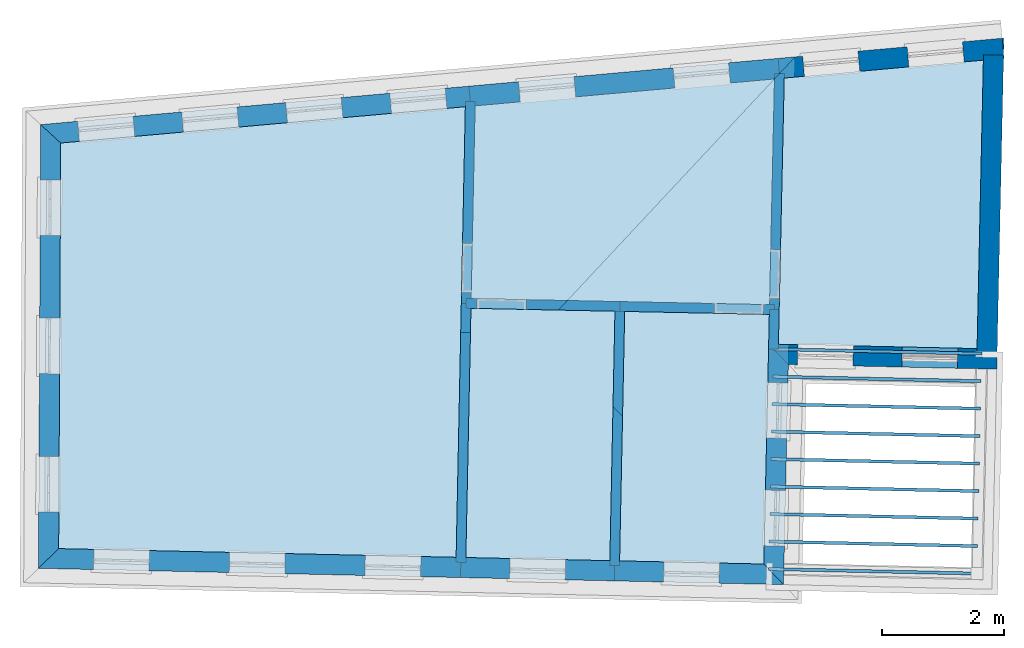
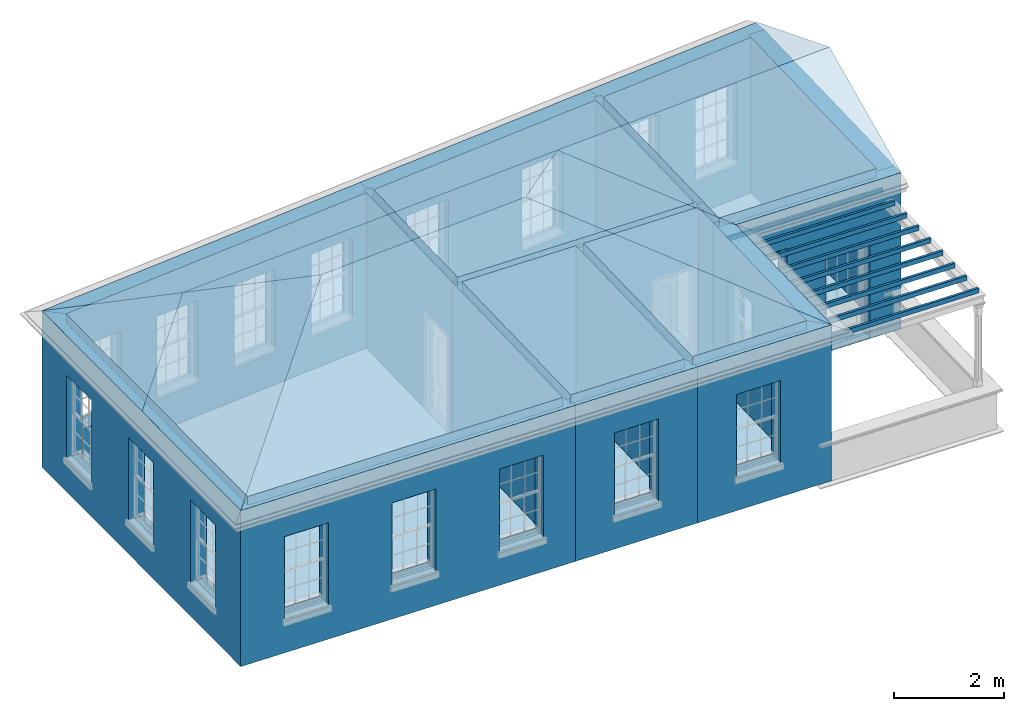
# One storey, part 1 of 14: 18 slabs, 17 walls, 2 roofs, 24 openings.
"""IFC2X3 building model written with IfcOpenShell, lengths in metres."""

from ifc_helpers import new_model, si_unit, frame, origin, place, context, subcontext, project, spatial, polyline, outline, extrude, faceted_brep, material, layer, layer_set, layer_usage, element, save


model = new_model("IFC2X3")

# Units and contexts
model_context = context("Model", 3, world=origin())
body_context = subcontext(model_context, "Body", "Model", "MODEL_VIEW")
ifc_project = project(units=[si_unit("PLANEANGLEUNIT", "RADIAN"), si_unit("MASSUNIT", "GRAM", prefix="KILO"), si_unit("FORCEUNIT", "NEWTON", prefix="KILO"), si_unit("LENGTHUNIT", "METRE")], contexts=[model_context])

# Site, building, storey
site_placement = place(None, origin())
site = spatial("IfcSite", under=ifc_project, at=site_placement, CompositionType="ELEMENT")
building_placement = place(None, origin())
building = spatial("IfcBuilding", under=site, at=building_placement, Name="Building plot-17", CompositionType="ELEMENT")
storey_placement = place(None, frame((0.0, 0.0, 6.15)))
storey = spatial("IfcBuildingStorey", under=building, at=storey_placement, Name="Floor 1", CompositionType="ELEMENT", Elevation=6.15)

# Slabs
slab_1_placement = place(storey_placement, frame((0.0, 0.0, 3.25)))
element("IfcSlab", 1, at=slab_1_placement, inside=storey, Name="Slab", ObjectType="Slab", PredefinedType="FLOOR", context=body_context, shape_type="SweptSolid", body=[
    extrude(outline(polyline([(85.7393487222941, 22.0938601884115), (85.8425989058895, 26.8144504761044), (82.5834149093309, 26.5217011344998), (82.488123206876, 22.1649719797169), (85.7393487222941, 22.0938601884115)])), origin(), (0.0, 0.0, 1.0), 0.2),
])
slab_2_placement = place(storey_placement, frame((0.0, 0.0, 2.95)))
element("IfcSlab", 2, at=slab_2_placement, inside=storey, Name="Slab", ObjectType="Slab", PredefinedType="FLOOR", context=body_context, shape_type="SweptSolid", body=[
    extrude(outline(polyline([(85.7382573208304, 18.3854928925304), (85.739350674509, 18.4354809368784), (82.3281634171773, 18.5100914599554), (82.3270700634987, 18.4601034156075), (85.7382573208304, 18.3854928925304)])), origin(), (0.0, 0.0, 1.0), 0.1),
])
slab_3_placement = place(storey_placement, frame((0.0, 0.0, 2.95)))
element("IfcSlab", 3, at=slab_3_placement, inside=storey, Name="Slab", ObjectType="Slab", PredefinedType="FLOOR", context=body_context, shape_type="SweptSolid", body=[
    extrude(outline(polyline([(85.7480975039383, 18.835385291662), (85.749190857617, 18.88537333601), (82.3380036002853, 18.959983859087), (82.3369102466066, 18.9099958147391), (85.7480975039383, 18.835385291662)])), origin(), (0.0, 0.0, 1.0), 0.1),
])
slab_4_placement = place(storey_placement, frame((0.0, 0.0, 2.95)))
element("IfcSlab", 4, at=slab_4_placement, inside=storey, Name="Slab", ObjectType="Slab", PredefinedType="FLOOR", context=body_context, shape_type="SweptSolid", body=[
    extrude(outline(polyline([(85.7579376870462, 19.2852776907937), (85.7590310407249, 19.3352657351416), (82.3478437833932, 19.4098762582186), (82.3467504297146, 19.3598882138707), (85.7579376870462, 19.2852776907937)])), origin(), (0.0, 0.0, 1.0), 0.1),
])
slab_5_placement = place(storey_placement, frame((0.0, 0.0, 2.95)))
element("IfcSlab", 5, at=slab_5_placement, inside=storey, Name="Slab", ObjectType="Slab", PredefinedType="FLOOR", context=body_context, shape_type="SweptSolid", body=[
    extrude(outline(polyline([(85.7677778701542, 19.7351700899253), (85.7688712238328, 19.7851581342732), (82.3576839665012, 19.8597686573503), (82.3565906128225, 19.8097806130023), (85.7677778701542, 19.7351700899253)])), origin(), (0.0, 0.0, 1.0), 0.1),
])
slab_6_placement = place(storey_placement, frame((0.0, 0.0, 2.95)))
element("IfcSlab", 6, at=slab_6_placement, inside=storey, Name="Slab", ObjectType="Slab", PredefinedType="FLOOR", context=body_context, shape_type="SweptSolid", body=[
    extrude(outline(polyline([(85.7776180532621, 20.1850624890569), (85.7787114069408, 20.2350505334048), (82.3675241496091, 20.3096610564819), (82.3664307959305, 20.2596730121339), (85.7776180532621, 20.1850624890569)])), origin(), (0.0, 0.0, 1.0), 0.1),
])
slab_7_placement = place(storey_placement, frame((0.0, 0.0, 2.95)))
element("IfcSlab", 7, at=slab_7_placement, inside=storey, Name="Slab", ObjectType="Slab", PredefinedType="FLOOR", context=body_context, shape_type="SweptSolid", body=[
    extrude(outline(polyline([(85.78745823637, 20.6349548881885), (85.7885515900487, 20.6849429325365), (82.3773643327171, 20.7595534556135), (82.3762709790384, 20.7095654112655), (85.78745823637, 20.6349548881885)])), origin(), (0.0, 0.0, 1.0), 0.1),
])
slab_8_placement = place(storey_placement, frame((0.0, 0.0, 2.95)))
element("IfcSlab", 8, at=slab_8_placement, inside=storey, Name="Slab", ObjectType="Slab", PredefinedType="FLOOR", context=body_context, shape_type="SweptSolid", body=[
    extrude(outline(polyline([(85.797298419478, 21.0848472873201), (85.7983917731566, 21.1348353316681), (82.387204515825, 21.2094458547451), (82.3861111621463, 21.1594578103972), (85.797298419478, 21.0848472873201)])), origin(), (0.0, 0.0, 1.0), 0.1),
])
slab_9_placement = place(storey_placement, frame((0.0, 0.0, 2.95)))
element("IfcSlab", 9, at=slab_9_placement, inside=storey, Name="Slab", ObjectType="Slab", PredefinedType="FLOOR", context=body_context, shape_type="SweptSolid", body=[
    extrude(outline(polyline([(85.8071386025859, 21.5347396864517), (85.8082319562646, 21.5847277307997), (82.397044698933, 21.6593382538767), (82.3959513452543, 21.6093502095288), (85.8071386025859, 21.5347396864517)])), origin(), (0.0, 0.0, 1.0), 0.1),
])
slab_10_placement = place(storey_placement, frame((0.0, 0.0, 2.95)))
element("IfcSlab", 10, at=slab_10_placement, inside=storey, Name="Slab", ObjectType="Slab", PredefinedType="FLOOR", context=body_context, shape_type="SweptSolid", body=[
    extrude(outline(polyline([(85.8169787856938, 21.9846320855834), (85.8180721393725, 22.0346201299313), (82.4068848820409, 22.1092306530083), (82.4057915283622, 22.0592426086604), (85.8169787856938, 21.9846320855834)])), origin(), (0.0, 0.0, 1.0), 0.1),
])
slab_11_placement = place(storey_placement, frame((0.0, 0.0, 3.25)))
element("IfcSlab", 11, at=slab_11_placement, inside=storey, Name="Slab", ObjectType="Slab", PredefinedType="FLOOR", context=body_context, shape_type="SweptSolid", body=[
    extrude(outline(polyline([(77.3625338918575, 26.0527464875477), (70.7400454135505, 25.4578954009408), (70.7063349193503, 18.8193007747523), (77.2119597454112, 18.6770077739289), (77.3625338918575, 26.0527464875477)])), origin(), (0.0, 0.0, 1.0), 0.2),
])
slab_12_placement = place(storey_placement, frame((0.0, 0.0, 3.25)))
element("IfcSlab", 12, at=slab_12_placement, inside=storey, Name="Slab", ObjectType="Slab", PredefinedType="FLOOR", context=body_context, shape_type="SweptSolid", body=[
    extrude(outline(polyline([(77.3719216570803, 18.6735090384441), (79.728438199853, 18.6219665933562), (79.8117822482766, 22.7044996112409), (77.4551956168955, 22.7526088290867), (77.3719216570803, 18.6735090384441)])), origin(), (0.0, 0.0, 1.0), 0.2),
])
slab_13_placement = place(storey_placement, frame((0.0, 0.0, 3.25)))
element("IfcSlab", 13, at=slab_13_placement, inside=storey, Name="Slab", ObjectType="Slab", PredefinedType="FLOOR", context=body_context, shape_type="SweptSolid", body=[
    extrude(outline(polyline([(82.3422560462478, 22.812873861267), (82.4230616066043, 26.5072977366408), (77.5228612241715, 26.0671475526688), (77.4584613026294, 22.912575498417), (82.3422560462478, 22.812873861267)])), origin(), (0.0, 0.0, 1.0), 0.2),
])
slab_14_placement = place(storey_placement, frame((0.0, 0.0, 3.25)))
element("IfcSlab", 14, at=slab_14_placement, inside=storey, Name="Slab", ObjectType="Slab", PredefinedType="FLOOR", context=body_context, shape_type="SweptSolid", body=[
    extrude(outline(polyline([(79.8884001115221, 18.6184678578716), (82.2493852352671, 18.5668276746241), (82.3387573107631, 22.6529119495976), (79.9717489176071, 22.701233925507), (79.8884001115221, 18.6184678578716)])), origin(), (0.0, 0.0, 1.0), 0.2),
])
slab_15_placement = place(storey_placement, origin())
element("IfcSlab", 15, at=slab_15_placement, inside=storey, Name="Slab", ObjectType="Slab", PredefinedType="FLOOR", context=body_context, shape_type="SweptSolid", body=[
    extrude(outline(polyline([(85.7393487222941, 22.0938601884115), (85.8425989058895, 26.8144504761044), (82.5834149093309, 26.5217011344998), (82.488123206876, 22.1649719797169), (85.7393487222941, 22.0938601884115)])), origin(), (0.0, 0.0, 1.0), 0.02),
])
slab_16_placement = place(storey_placement, origin())
element("IfcSlab", 16, at=slab_16_placement, inside=storey, Name="Slab", ObjectType="Slab", PredefinedType="FLOOR", context=body_context, shape_type="SweptSolid", body=[
    extrude(outline(polyline([(77.3625338918575, 26.0527464875477), (70.7400454135505, 25.4578954009408), (70.7063349193503, 18.8193007747523), (77.2119597454112, 18.6770077739289), (77.3625338918575, 26.0527464875477)])), origin(), (0.0, 0.0, 1.0), 0.02),
])
slab_17_placement = place(storey_placement, origin())
element("IfcSlab", 17, at=slab_17_placement, inside=storey, Name="Slab", ObjectType="Slab", PredefinedType="FLOOR", context=body_context, shape_type="SweptSolid", body=[
    extrude(outline(polyline([(77.3719216570803, 18.6735090384441), (79.728438199853, 18.6219665933562), (79.8117822482766, 22.7044996112409), (77.4551956168955, 22.7526088290867), (77.3719216570803, 18.6735090384441)])), origin(), (0.0, 0.0, 1.0), 0.02),
])
slab_18_placement = place(storey_placement, origin())
element("IfcSlab", 18, at=slab_18_placement, inside=storey, Name="Slab", ObjectType="Slab", PredefinedType="FLOOR", context=body_context, shape_type="SweptSolid", body=[
    extrude(outline(polyline([(79.8884001115221, 18.6184678578716), (82.2493852352671, 18.5668276746241), (82.3387573107631, 22.6529119495976), (79.9717489176071, 22.701233925507), (79.8884001115221, 18.6184678578716)])), origin(), (0.0, 0.0, 1.0), 0.02),
])

# Wall, openings
ifc_material_1 = material(Name="Masonry")
ifc_layer_1 = layer(ifc_material_1, 0.33, ventilated=False)
ifc_layer_set_1 = layer_set([ifc_layer_1], Name="My Wall")
ifc_layer_usage_1 = layer_usage(ifc_layer_set_1, "AXIS2", "NEGATIVE", 0.08)
wall_1_placement = place(storey_placement, origin())
wall_1 = element("IfcWallStandardCase", 19, at=wall_1_placement, inside=storey, material=ifc_layer_usage_1, Name="exterior", context=body_context, shape_type="SweptSolid", body=[
    extrude(outline(polyline([(86.1806904049411, 26.8448188332919), (86.1511677071765, 27.173495589873), (82.4826328650269, 26.8439771702856), (82.5121555627915, 26.5153004137045), (86.1806904049411, 26.8448188332919)])), origin(), (0.0, 0.0, 1.0), 3.45),
])
opening_1_placement = place(storey_placement, frame((0.0, 0.0, 0.75)))
element("IfcOpeningElement", 20, at=opening_1_placement, cuts=wall_1, Name="Opening", ObjectType="Opening", context=body_context, shape_type="SweptSolid", body=[
    extrude(outline(polyline([(85.5004613675041, 27.1150472627096), (84.5941103114773, 27.0336361870557), (84.6236330092419, 26.7049594304745), (85.5299840652687, 26.7863705061284), (85.5004613675041, 27.1150472627096)])), origin(), (0.0, 0.0, 1.0), 1.82),
])
opening_2_placement = place(storey_placement, frame((0.0, 0.0, 0.75)))
element("IfcOpeningElement", 21, at=opening_2_placement, cuts=wall_1, Name="Opening", ObjectType="Opening", context=body_context, shape_type="SweptSolid", body=[
    extrude(outline(polyline([(83.7906927178616, 26.9614708929782), (82.8843416618348, 26.8800598173243), (82.9138643595994, 26.5513830607432), (83.8202154156262, 26.6327941363971), (83.7906927178616, 26.9614708929782)])), origin(), (0.0, 0.0, 1.0), 1.82),
])

wall_2_placement = place(storey_placement, origin())
wall_2 = element("IfcWallStandardCase", 22, at=wall_2_placement, inside=storey, material=ifc_layer_usage_1, Name="exterior", context=body_context, shape_type="SweptSolid", body=[
    extrude(outline(polyline([(82.5121555627915, 26.5153004137045), (82.4826328650269, 26.8439771702856), (77.4219746484992, 26.3894141991445), (77.4514973462638, 26.0607374425634), (82.5121555627915, 26.5153004137045)])), origin(), (0.0, 0.0, 1.0), 3.45),
])
opening_3_placement = place(storey_placement, frame((0.0, 0.0, 0.75)))
element("IfcOpeningElement", 23, at=opening_3_placement, cuts=wall_2, Name="Opening", ObjectType="Opening", context=body_context, shape_type="SweptSolid", body=[
    extrude(outline(polyline([(81.6706438389084, 26.7710419653273), (80.7642927828816, 26.6896308896734), (80.7938154806462, 26.3609541330922), (81.700166536673, 26.4423652087461), (81.6706438389084, 26.7710419653273)])), origin(), (0.0, 0.0, 1.0), 1.82),
])
opening_4_placement = place(storey_placement, frame((0.0, 0.0, 0.75)))
element("IfcOpeningElement", 24, at=opening_4_placement, cuts=wall_2, Name="Opening", ObjectType="Opening", context=body_context, shape_type="SweptSolid", body=[
    extrude(outline(polyline([(79.1403147306445, 26.5437604797567), (78.2339636746177, 26.4623494041028), (78.2634863723823, 26.1336726475217), (79.1698374284091, 26.2150837231756), (79.1403147306445, 26.5437604797567)])), origin(), (0.0, 0.0, 1.0), 1.82),
])

wall_3_placement = place(storey_placement, origin())
wall_3 = element("IfcWallStandardCase", 25, at=wall_3_placement, inside=storey, material=ifc_layer_usage_1, Name="exterior", context=body_context, shape_type="SweptSolid", body=[
    extrude(outline(polyline([(77.4514973462638, 26.0607374425634), (77.4219746484992, 26.3894141991445), (70.4115738095909, 25.7597197013384), (70.7400454135505, 25.4578954009408), (77.4514973462638, 26.0607374425634)])), origin(), (0.0, 0.0, 1.0), 3.45),
])
opening_5_placement = place(storey_placement, frame((0.0, 0.0, 0.75)))
element("IfcOpeningElement", 26, at=opening_5_placement, cuts=wall_3, Name="Opening", ObjectType="Opening", context=body_context, shape_type="SweptSolid", body=[
    extrude(outline(polyline([(77.0323071544384, 26.354413136777), (76.1259560984116, 26.273002061123), (76.1554787961762, 25.9443253045419), (77.061829852203, 26.0257363801958), (77.0323071544384, 26.354413136777)])), origin(), (0.0, 0.0, 1.0), 1.82),
])
opening_6_placement = place(storey_placement, frame((0.0, 0.0, 0.75)))
element("IfcOpeningElement", 27, at=opening_6_placement, cuts=wall_3, Name="Opening", ObjectType="Opening", context=body_context, shape_type="SweptSolid", body=[
    extrude(outline(polyline([(75.3291639612452, 26.201431884724), (74.4228129052184, 26.12002080907), (74.452335602983, 25.7913440524889), (75.3586866590098, 25.8727551281428), (75.3291639612452, 26.201431884724)])), origin(), (0.0, 0.0, 1.0), 1.82),
])
opening_7_placement = place(storey_placement, frame((0.0, 0.0, 0.75)))
element("IfcOpeningElement", 28, at=opening_7_placement, cuts=wall_3, Name="Opening", ObjectType="Opening", context=body_context, shape_type="SweptSolid", body=[
    extrude(outline(polyline([(73.626020768052, 26.0484506326709), (72.7196697120252, 25.967039557017), (72.7491924097898, 25.6383628004358), (73.6555434658166, 25.7197738760898), (73.626020768052, 26.0484506326709)])), origin(), (0.0, 0.0, 1.0), 1.82),
])
opening_8_placement = place(storey_placement, frame((0.0, 0.0, 0.75)))
element("IfcOpeningElement", 29, at=opening_8_placement, cuts=wall_3, Name="Opening", ObjectType="Opening", context=body_context, shape_type="SweptSolid", body=[
    extrude(outline(polyline([(71.9228775748588, 25.8954693806179), (71.016526518832, 25.814058304964), (71.0460492165967, 25.4853815483828), (71.9524002726234, 25.5667926240368), (71.9228775748588, 25.8954693806179)])), origin(), (0.0, 0.0, 1.0), 1.82),
])

wall_4_placement = place(storey_placement, origin())
wall_4 = element("IfcWallStandardCase", 30, at=wall_4_placement, inside=storey, material=ifc_layer_usage_1, Name="exterior", context=body_context, shape_type="SweptSolid", body=[
    extrude(outline(polyline([(70.7400454135505, 25.4578954009408), (70.4115738095909, 25.7597197013384), (70.3746913728671, 18.4964756568879), (70.7063349193503, 18.8193007747523), (70.7400454135505, 25.4578954009408)])), origin(), (0.0, 0.0, 1.0), 3.45),
])
opening_9_placement = place(storey_placement, frame((0.0, 0.0, 0.75)))
element("IfcOpeningElement", 31, at=opening_9_placement, cuts=wall_4, Name="Opening", ObjectType="Opening", context=body_context, shape_type="SweptSolid", body=[
    extrude(outline(polyline([(70.4069830223347, 24.855657736896), (70.4023621415685, 23.9456694691359), (70.73235788702, 23.9439937651218), (70.7369787677862, 24.8539820328818), (70.4069830223347, 24.855657736896)])), origin(), (0.0, 0.0, 1.0), 1.82),
])
opening_10_placement = place(storey_placement, frame((0.0, 0.0, 0.75)))
element("IfcOpeningElement", 32, at=opening_10_placement, cuts=wall_4, Name="Opening", ObjectType="Opening", context=body_context, shape_type="SweptSolid", body=[
    extrude(outline(polyline([(70.3954898723469, 22.5923161408321), (70.3908689915807, 21.682327873072), (70.7208647370322, 21.6806521690579), (70.7254856177983, 22.590640436818), (70.3954898723469, 22.5923161408321)])), origin(), (0.0, 0.0, 1.0), 1.82),
])
opening_11_placement = place(storey_placement, frame((0.0, 0.0, 0.75)))
element("IfcOpeningElement", 33, at=opening_11_placement, cuts=wall_4, Name="Opening", ObjectType="Opening", context=body_context, shape_type="SweptSolid", body=[
    extrude(outline(polyline([(70.383996722359, 20.3289745447682), (70.3793758415929, 19.4189862770082), (70.7093715870443, 19.4173105729941), (70.7139924678105, 20.3272988407541), (70.383996722359, 20.3289745447682)])), origin(), (0.0, 0.0, 1.0), 1.82),
])

wall_5_placement = place(storey_placement, origin())
wall_5 = element("IfcWallStandardCase", 34, at=wall_5_placement, inside=storey, material=ifc_layer_usage_1, Name="exterior", context=body_context, shape_type="SweptSolid", body=[
    extrude(outline(polyline([(70.7063349193503, 18.8193007747523), (70.3746913728671, 18.4964756568879), (77.2848410882527, 18.3453347649011), (77.2920572225319, 18.6752558575976), (70.7063349193503, 18.8193007747523)])), origin(), (0.0, 0.0, 1.0), 3.45),
])
opening_12_placement = place(storey_placement, frame((0.0, 0.0, 0.75)))
element("IfcOpeningElement", 35, at=opening_12_placement, cuts=wall_5, Name="Opening", ObjectType="Opening", context=body_context, shape_type="SweptSolid", body=[
    extrude(outline(polyline([(71.2763070740139, 18.4767552446081), (72.1860894811468, 18.4568562076565), (72.1933056154259, 18.786777300353), (71.2835232082931, 18.8066763373046), (71.2763070740139, 18.4767552446081)])), origin(), (0.0, 0.0, 1.0), 1.82),
])
opening_13_placement = place(storey_placement, frame((0.0, 0.0, 0.75)))
element("IfcOpeningElement", 36, at=opening_13_placement, cuts=wall_5, Name="Opening", ObjectType="Opening", context=body_context, shape_type="SweptSolid", body=[
    extrude(outline(polyline([(73.4977641982829, 18.4281668601156), (74.4075466054157, 18.408267823164), (74.4147627396949, 18.7381889158605), (73.504980332562, 18.7580879528121), (73.4977641982829, 18.4281668601156)])), origin(), (0.0, 0.0, 1.0), 1.82),
])
opening_14_placement = place(storey_placement, frame((0.0, 0.0, 0.75)))
element("IfcOpeningElement", 37, at=opening_14_placement, cuts=wall_5, Name="Opening", ObjectType="Opening", context=body_context, shape_type="SweptSolid", body=[
    extrude(outline(polyline([(75.7192213225518, 18.3795784756232), (76.6290037296846, 18.3596794386715), (76.6362198639638, 18.6896005313681), (75.726437456831, 18.7094995683197), (75.7192213225518, 18.3795784756232)])), origin(), (0.0, 0.0, 1.0), 1.82),
])

# Wall, opening
wall_6_placement = place(storey_placement, origin())
wall_6 = element("IfcWallStandardCase", 38, at=wall_6_placement, inside=storey, material=ifc_layer_usage_1, Name="exterior", context=body_context, shape_type="SweptSolid", body=[
    extrude(outline(polyline([(77.2920572225319, 18.6752558575976), (77.2848410882527, 18.3453347649011), (79.8013195426945, 18.2902935843284), (79.8085356769737, 18.6202146770249), (77.2920572225319, 18.6752558575976)])), origin(), (0.0, 0.0, 1.0), 3.45),
])
opening_15_placement = place(storey_placement, frame((0.0, 0.0, 0.75)))
element("IfcOpeningElement", 39, at=opening_15_placement, cuts=wall_6, Name="Opening", ObjectType="Opening", context=body_context, shape_type="SweptSolid", body=[
    extrude(outline(polyline([(78.0881891119072, 18.3277636930906), (78.99797151904, 18.307864656139), (79.0051876533192, 18.6377857488355), (78.0954052461863, 18.6576847857871), (78.0881891119072, 18.3277636930906)])), origin(), (0.0, 0.0, 1.0), 1.82),
])

wall_7_placement = place(storey_placement, origin())
wall_7 = element("IfcWallStandardCase", 40, at=wall_7_placement, inside=storey, material=ifc_layer_usage_1, Name="exterior", context=body_context, shape_type="SweptSolid", body=[
    extrude(outline(polyline([(79.8085356769737, 18.6202146770249), (79.8013195426945, 18.2902935843284), (82.5720901936845, 18.2296904476484), (82.2493852352671, 18.5668276746241), (79.8085356769737, 18.6202146770249)])), origin(), (0.0, 0.0, 1.0), 3.45),
])
opening_16_placement = place(storey_placement, frame((0.0, 0.0, 0.75)))
element("IfcOpeningElement", 41, at=opening_16_placement, cuts=wall_7, Name="Opening", ObjectType="Opening", context=body_context, shape_type="SweptSolid", body=[
    extrude(outline(polyline([(80.6068435537532, 18.2726749186609), (81.516625960886, 18.2527758817093), (81.5238420951652, 18.5826969744058), (80.6140596880323, 18.6025960113574), (80.6068435537532, 18.2726749186609)])), origin(), (0.0, 0.0, 1.0), 1.82),
])

# Wall, openings
wall_8_placement = place(storey_placement, origin())
wall_8 = element("IfcWallStandardCase", 42, at=wall_8_placement, inside=storey, material=ifc_layer_usage_1, Name="exterior", context=body_context, shape_type="SweptSolid", body=[
    extrude(outline(polyline([(82.2493852352671, 18.5668276746241), (82.5720901936845, 18.2296904476484), (82.6508664233799, 21.8313334845129), (82.3281614649625, 22.1684707114887), (82.2493852352671, 18.5668276746241)])), origin(), (0.0, 0.0, 1.0), 3.45),
])
opening_17_placement = place(storey_placement, frame((0.0, 0.0, 0.75)))
element("IfcOpeningElement", 43, at=opening_17_placement, cuts=wall_8, Name="Opening", ObjectType="Opening", context=body_context, shape_type="SweptSolid", body=[
    extrude(outline(polyline([(82.5858664500356, 18.8595398064327), (82.6057654869872, 19.7693222135655), (82.2758443942907, 19.7765383478447), (82.2559453573391, 18.8667559407118), (82.5858664500356, 18.8595398064327)])), origin(), (0.0, 0.0, 1.0), 1.82),
])
opening_18_placement = place(storey_placement, frame((0.0, 0.0, 0.75)))
element("IfcOpeningElement", 44, at=opening_18_placement, cuts=wall_8, Name="Opening", ObjectType="Opening", context=body_context, shape_type="SweptSolid", body=[
    extrude(outline(polyline([(82.6244072643563, 20.6216228112923), (82.6443063013079, 21.5314052184252), (82.3143852086114, 21.5386213527043), (82.2944861716598, 20.6288389455715), (82.6244072643563, 20.6216228112923)])), origin(), (0.0, 0.0, 1.0), 1.82),
])

wall_9_placement = place(storey_placement, origin())
wall_9 = element("IfcWallStandardCase", 45, at=wall_9_placement, inside=storey, material=ifc_layer_usage_1, Name="exterior", context=body_context, shape_type="SweptSolid", body=[
    extrude(outline(polyline([(82.3281614649625, 22.1684707114887), (82.6508664233799, 21.8313334845129), (86.0620536807115, 21.7567229614358), (86.0692698149906, 22.0866440541323), (82.3281614649625, 22.1684707114887)])), origin(), (0.0, 0.0, 1.0), 3.45),
])
opening_19_placement = place(storey_placement, frame((0.0, 0.0, 0.75)))
element("IfcOpeningElement", 46, at=opening_19_placement, cuts=wall_9, Name="Opening", ObjectType="Opening", context=body_context, shape_type="SweptSolid", body=[
    extrude(outline(polyline([(82.7988318124066, 21.8280971406127), (83.7086142195394, 21.8081981036611), (83.7158303538186, 22.1381191963576), (82.8060479466857, 22.1580182333093), (82.7988318124066, 21.8280971406127)])), origin(), (0.0, 0.0, 1.0), 1.82),
])
opening_20_placement = place(storey_placement, frame((0.0, 0.0, 0.0199999999999996)))
element("IfcOpeningElement", 47, at=opening_20_placement, cuts=wall_9, Name="Opening", ObjectType="Opening", context=body_context, shape_type="SweptSolid", body=[
    extrude(outline(polyline([(84.5084229291067, 21.7907044448026), (85.4182053362396, 21.770805407851), (85.4254214705187, 22.1007265005475), (84.5156390633859, 22.1206255374991), (84.5084229291067, 21.7907044448026)])), origin(), (0.0, 0.0, 1.0), 2.08),
])

# Wall
wall_10_placement = place(storey_placement, origin())
element("IfcWallStandardCase", 48, at=wall_10_placement, inside=storey, material=ifc_layer_usage_1, Name="party", context=body_context, shape_type="SweptSolid", body=[
    extrude(outline(polyline([(85.7375993564083, 22.0138793174548), (86.0675204491048, 22.0066631831756), (86.1744760661765, 26.8966655984905), (85.84455497348, 26.9038817327697), (85.7375993564083, 22.0138793174548)])), origin(), (0.0, 0.0, 1.0), 3.45),
])

# Wall, opening
ifc_material_2 = material(Name="Masonry")
ifc_layer_2 = layer(ifc_material_2, 0.16, ventilated=False)
ifc_layer_set_2 = layer_set([ifc_layer_2], Name="My Wall")
ifc_layer_usage_2 = layer_usage(ifc_layer_set_2, "AXIS2", "NEGATIVE", 0.08)
wall_11_placement = place(storey_placement, origin())
wall_11 = element("IfcWallStandardCase", 49, at=wall_11_placement, inside=storey, material=ifc_layer_usage_2, Name="interior", context=body_context, shape_type="SweptSolid", body=[
    extrude(outline(polyline([(77.3784779679642, 22.9142083412841), (77.3752122822302, 22.7542416719537), (79.8917655829418, 22.702866768374), (79.8950312686758, 22.8628334377044), (77.3784779679642, 22.9142083412841)])), origin(), (0.0, 0.0, 1.0), 3.45),
])
opening_21_placement = place(storey_placement, frame((0.0, 0.0, 0.0199999999999996)))
element("IfcOpeningElement", 50, at=opening_21_placement, cuts=wall_11, Name="Opening", ObjectType="Opening", context=body_context, shape_type="SweptSolid", body=[
    extrude(outline(polyline([(77.555174785227, 22.750567775503), (78.3550081318794, 22.7342393468333), (78.3582738176134, 22.8942060161638), (77.558440470961, 22.9105344448335), (77.555174785227, 22.750567775503)])), origin(), (0.0, 0.0, 1.0), 2.1),
])

wall_12_placement = place(storey_placement, origin())
wall_12 = element("IfcWallStandardCase", 51, at=wall_12_placement, inside=storey, material=ifc_layer_usage_2, Name="interior", context=body_context, shape_type="SweptSolid", body=[
    extrude(outline(polyline([(82.5849794161083, 26.5932302615352), (82.4250176741949, 26.596728993307), (82.3405092270944, 22.7330094267186), (82.5004709690078, 22.7295106949468), (82.5849794161083, 26.5932302615352)])), origin(), (0.0, 0.0, 1.0), 3.45),
])
opening_22_placement = place(storey_placement, frame((0.0, 0.0, 0.0199999999999996)))
element("IfcOpeningElement", 52, at=opening_22_placement, cuts=wall_12, Name="Opening", ObjectType="Opening", context=body_context, shape_type="SweptSolid", body=[
    extrude(outline(polyline([(82.3619389591961, 23.7127750959385), (82.3444453003375, 22.9129663863712), (82.504407042251, 22.9094676545995), (82.5219007011096, 23.7092763641668), (82.3619389591961, 23.7127750959385)])), origin(), (0.0, 0.0, 1.0), 2.1),
])

wall_13_placement = place(storey_placement, origin())
wall_13 = element("IfcWallStandardCase", 53, at=wall_13_placement, inside=storey, material=ifc_layer_usage_2, Name="interior", context=body_context, shape_type="SweptSolid", body=[
    extrude(outline(polyline([(77.296861790432, 22.8358578494859), (77.4568284597624, 22.8325921637519), (77.5243236632891, 26.138783813413), (77.3643569939587, 26.142049499147), (77.296861790432, 22.8358578494859)])), origin(), (0.0, 0.0, 1.0), 3.45),
])
opening_23_placement = place(storey_placement, frame((0.0, 0.0, 0.0199999999999996)))
element("IfcOpeningElement", 54, at=opening_23_placement, cuts=wall_13, Name="Opening", ObjectType="Opening", context=body_context, shape_type="SweptSolid", body=[
    extrude(outline(polyline([(77.4605023562131, 23.0125546667487), (77.4768307848828, 23.8123880134011), (77.3168641155523, 23.8156536991351), (77.3005356868826, 23.0158203524827), (77.4605023562131, 23.0125546667487)])), origin(), (0.0, 0.0, 1.0), 2.1),
])

# Wall
wall_14_placement = place(storey_placement, origin())
element("IfcWallStandardCase", 55, at=wall_14_placement, inside=storey, material=ifc_layer_usage_2, Name="interior", context=body_context, shape_type="SweptSolid", body=[
    extrude(outline(polyline([(82.5004709690078, 22.7295106949468), (82.3405092270944, 22.7330094267186), (82.3264120990767, 22.0884898405319), (82.4863738409901, 22.0849911087601), (82.5004709690078, 22.7295106949468)])), origin(), (0.0, 0.0, 1.0), 3.45),
])

# Wall, opening
wall_15_placement = place(storey_placement, origin())
wall_15 = element("IfcWallStandardCase", 56, at=wall_15_placement, inside=storey, material=ifc_layer_usage_2, Name="interior", context=body_context, shape_type="SweptSolid", body=[
    extrude(outline(polyline([(82.4188572551841, 22.6512767261675), (82.4221229409181, 22.8112433954979), (79.8950312686758, 22.8628334377044), (79.8917655829418, 22.702866768374), (82.4188572551841, 22.6512767261675)])), origin(), (0.0, 0.0, 1.0), 3.45),
])
opening_24_placement = place(storey_placement, frame((0.0, 0.0, 0.0199999999999996)))
element("IfcOpeningElement", 57, at=opening_24_placement, cuts=wall_15, Name="Opening", ObjectType="Opening", context=body_context, shape_type="SweptSolid", body=[
    extrude(outline(polyline([(82.2421604379213, 22.8149172919486), (81.4423270912689, 22.8312457206183), (81.4390614055349, 22.6712790512878), (82.2388947521873, 22.6549506226181), (82.2421604379213, 22.8149172919486)])), origin(), (0.0, 0.0, 1.0), 2.1),
])

# Walls
wall_16_placement = place(storey_placement, origin())
element("IfcWallStandardCase", 58, at=wall_16_placement, inside=storey, material=ifc_layer_usage_2, Name="interior", context=body_context, shape_type="SweptSolid", body=[
    extrude(outline(polyline([(79.973381760474, 22.7812172601722), (79.8134150911436, 22.7844829459062), (79.7268029764226, 18.5418666489352), (79.886769645753, 18.5386009632012), (79.973381760474, 22.7812172601722)])), origin(), (0.0, 0.0, 1.0), 3.45),
])
wall_17_placement = place(storey_placement, origin())
element("IfcWallStandardCase", 59, at=wall_17_placement, inside=storey, material=ifc_layer_usage_2, Name="interior", context=body_context, shape_type="SweptSolid", body=[
    extrude(outline(polyline([(77.4568284597624, 22.8325921637519), (77.296861790432, 22.8358578494859), (77.2103245219808, 18.5969078295079), (77.3702911913112, 18.5936421437739), (77.4568284597624, 22.8325921637519)])), origin(), (0.0, 0.0, 1.0), 3.45),
])

# Roofs
roof_1_placement = place(building_placement, origin())
element("IfcRoof", 60, at=roof_1_placement, inside=storey, Name="Roof", ShapeType="FREEFORM", context=body_context, shape_type="Brep", held_by="IfcProductRepresentation", body=[
    faceted_brep([(70.374691, 18.496476, 9.6), (82.57209, 18.22969, 9.6), (78.582617, 22.397584, 11.28985), (74.230947, 22.250193, 11.189398), (82.761051, 26.868986, 9.6), (70.411574, 25.75972, 9.6)], [[[0, 1, 2, 3]], [[4, 5, 3, 2]], [[5, 4, 1, 0]], [[5, 0, 3]], [[1, 4, 2]]]),
])
roof_2_placement = place(building_placement, origin())
element("IfcRoof", 61, at=roof_2_placement, inside=storey, Name="Roof", ShapeType="FREEFORM", context=body_context, shape_type="Brep", held_by="IfcProductRepresentation", body=[
    faceted_brep([(70.392987, 22.099442, 9.6), (86.062054, 21.756723, 9.6), (86.121137, 24.457999, 10.719173), (72.336329, 23.99111, 10.40097), (86.180589, 27.176138, 9.6), (70.411574, 25.75972, 9.6)], [[[0, 1, 2, 3]], [[4, 5, 3, 2]], [[5, 4, 1, 0]], [[5, 0, 3]], [[1, 4, 2]]]),
])

save(model, "model.ifc")
